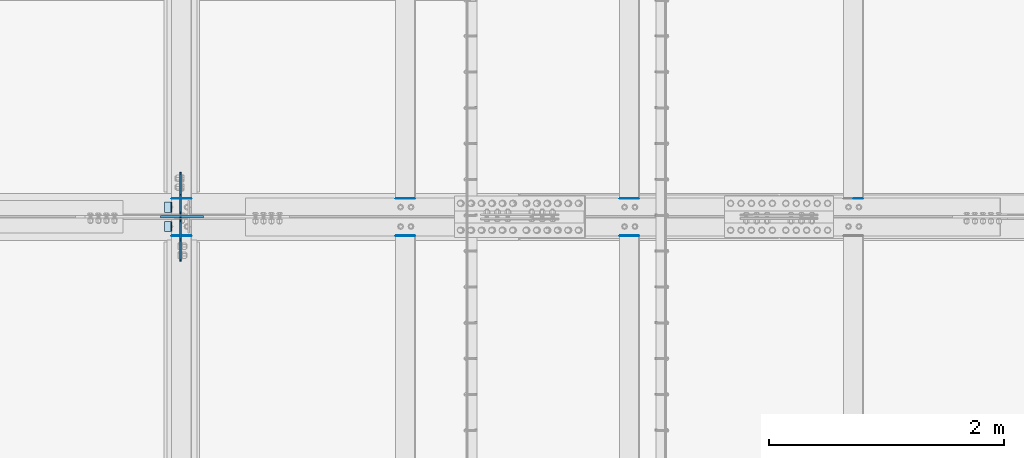
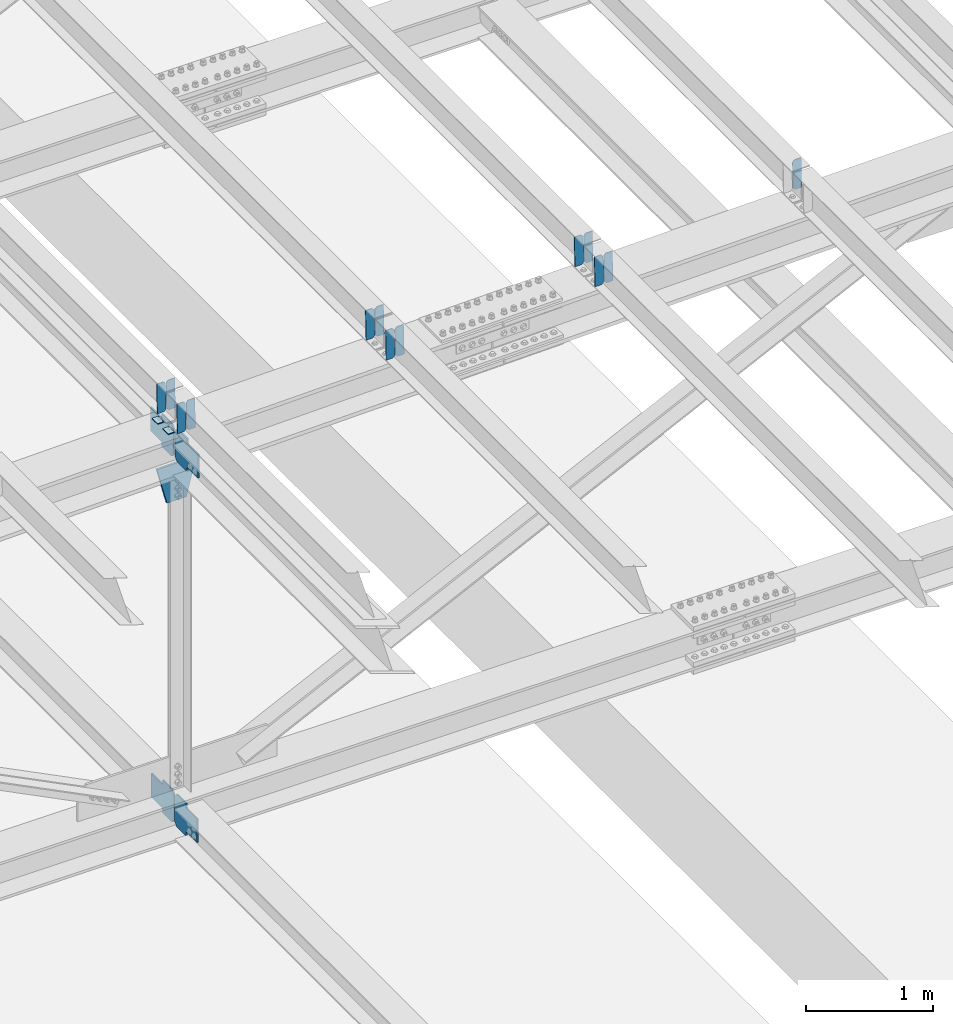
# One storey, part 3311 of 3843: 20 plates, 9 elements without a shape of their own.
"""IFC2X3 building model written with IfcOpenShell, lengths in millimetres."""

import ifcopenshell
import ifcopenshell.guid

model = None  # the IFC model being written
_history = None  # IfcOwnerHistory: only IFC2X3 demands one
_inside = {}  # id of a spatial element -> (the spatial element, [elements in it])
_under = {}  # id of a project, library or spatial element -> (it, [spatial elements below it])
_declared = {}  # id of a project -> (the project, [libraries it declares])
_typed = {}  # id of a type object -> (the type object, [elements of that type])
_made_of = {}  # id of a material, layer set ... -> (it, [elements and type objects made of it])


def new_model(schema):
    """Start an empty IFC model of exactly this schema.

    Asked for "IFC4X3", IfcOpenShell would pick the latest addendum, in which some entities
    have other attributes; the version numbers below select the first issue.
    IFC2X3 requires an IfcOwnerHistory on every rooted entity: one is made here for all.
    """
    global model, _history
    if schema == "IFC4X3":
        model = ifcopenshell.file(schema_version=(4, 3, 0, 0))
    else:
        model = ifcopenshell.file(schema=schema)
    _inside.clear()
    _under.clear()
    _declared.clear()
    _typed.clear()
    _made_of.clear()
    _history = None
    if model.schema == "IFC2X3":
        org = make("IfcOrganization", Name="unknown")
        user = make(
            "IfcPersonAndOrganization",
            ThePerson=make("IfcPerson", FamilyName="unknown"),
            TheOrganization=org,
        )
        app = make(
            "IfcApplication",
            ApplicationDeveloper=org,
            Version="unknown",
            ApplicationFullName="unknown",
            ApplicationIdentifier="unknown",
        )
        _history = make(
            "IfcOwnerHistory",
            OwningUser=user,
            OwningApplication=app,
            ChangeAction="ADDED",
            CreationDate=0,
        )
    return model


def make(cls, **values):
    """One entity of the class cls with the attributes given. An attribute that is None is left unset."""
    return model.create_entity(
        cls, **{name: value for name, value in values.items() if value is not None}
    )


def rooted(cls, **values):
    """An entity with a GlobalId (a new one), such as an element, a storey or a relation."""
    return make(cls, GlobalId=ifcopenshell.guid.new(), OwnerHistory=_history, **values)


def si_unit(unit_type, name, prefix=None):
    """IfcSIUnit, for example si_unit("LENGTHUNIT", "METRE", prefix="MILLI")."""
    return make("IfcSIUnit", UnitType=unit_type, Prefix=prefix, Name=name)


def assignment(units):
    """IfcUnitAssignment: the units of a project."""
    return None if units is None else make("IfcUnitAssignment", Units=units)


def point(xyz):
    """IfcCartesianPoint."""
    return None if xyz is None else make("IfcCartesianPoint", Coordinates=xyz)


def direction(xyz):
    """IfcDirection."""
    return None if xyz is None else make("IfcDirection", DirectionRatios=xyz)


def frame(location, z_axis=None, x_axis=None):
    """IfcAxis2Placement3D, a coordinate frame: its origin and axes. An axis left out is left unset."""
    return make(
        "IfcAxis2Placement3D",
        Location=point(location),
        Axis=direction(z_axis),
        RefDirection=direction(x_axis),
    )


def origin_with_axes():
    """The frame at (0, 0, 0) with the z axis (0, 0, 1) and the x axis (1, 0, 0) written out."""
    return frame((0.0, 0.0, 0.0), z_axis=(0.0, 0.0, 1.0), x_axis=(1.0, 0.0, 0.0))


def place(relative_to, where):
    """IfcLocalPlacement: puts the frame where relative to a parent placement (None: the world)."""
    return make(
        "IfcLocalPlacement", PlacementRelTo=relative_to, RelativePlacement=where
    )


def context(
    kind, dimensions, precision=None, world=None, true_north=None, identifier=None
):
    """IfcGeometricRepresentationContext, for example the 3D "Model" context."""
    return make(
        "IfcGeometricRepresentationContext",
        ContextIdentifier=identifier,
        ContextType=kind,
        CoordinateSpaceDimension=dimensions,
        Precision=precision,
        WorldCoordinateSystem=world,
        TrueNorth=true_north,
    )


def subcontext(parent, identifier, kind, view, scale=None):
    """IfcGeometricRepresentationSubContext, for example "Body" below "Model"."""
    return make(
        "IfcGeometricRepresentationSubContext",
        ContextIdentifier=identifier,
        ContextType=kind,
        ParentContext=parent,
        TargetScale=scale,
        TargetView=view,
    )


def project(units=None, contexts=None):
    """IfcProject with its units and contexts."""
    return rooted(
        "IfcProject",
        Name="project",
        RepresentationContexts=contexts,
        UnitsInContext=assignment(units),
    )


def spatial(cls, under=None, at=None, **own):
    """A site, building, storey or space (cls), placed at a placement, below another one or the project."""
    s = rooted(cls, ObjectPlacement=at, **own)
    if under is not None:
        _under.setdefault(under.id(), (under, []))[1].append(s)
    return s


def faces_of(points, faces, orient=None, outer=None):
    """IfcFace entities. A face is a list of loops; a loop is a list of indices into points, from 0.

    orient and outer hold one flag for each loop. By default every Orientation is true, the
    first loop of a face is its IfcFaceOuterBound and the others are IfcFaceBound.
    """
    made = []
    for i, loops in enumerate(faces):
        bounds = []
        for j, loop in enumerate(loops):
            is_outer = j == 0 if outer is None else outer[i][j]
            bounds.append(
                make(
                    "IfcFaceOuterBound" if is_outer else "IfcFaceBound",
                    Bound=make("IfcPolyLoop", Polygon=[points[k] for k in loop]),
                    Orientation=True if orient is None else orient[i][j],
                )
            )
        made.append(make("IfcFace", Bounds=bounds))
    return made


def faceted_brep(points, faces, orient=None, outer=None, voids=None):
    """IfcFacetedBrep: a solid bounded by flat faces; with voids (closed shells), ...WithVoids."""
    shared = [point(p) for p in points]
    hull = make("IfcClosedShell", CfsFaces=faces_of(shared, faces, orient, outer))
    if voids is None:
        return make("IfcFacetedBrep", Outer=hull)
    return make(
        "IfcFacetedBrepWithVoids",
        Outer=hull,
        Voids=[
            make(cls, CfsFaces=faces_of(shared, fs, o, b)) for cls, fs, o, b in voids
        ],
    )


def shape(context_of_items, identifier, shape_type, items):
    """IfcShapeRepresentation: the items that make up one representation, for example the "Body"."""
    return make(
        "IfcShapeRepresentation",
        ContextOfItems=context_of_items,
        RepresentationIdentifier=identifier,
        RepresentationType=shape_type,
        Items=items,
    )


def material(Name=None, Category=None):
    """IfcMaterial."""
    return make("IfcMaterial", Name=Name, Category=Category)


def made_of(thing, what):
    """Note that an element or type object is made of a material, layer set ...; save() writes the relation."""
    if what is not None:
        _made_of.setdefault(what.id(), (what, []))[1].append(thing)
    return thing


def type_object(cls, material=None, **own):
    """A type object (cls), such as IfcWallType, which elements share."""
    return made_of(rooted(cls, **own), material)


def element(
    cls,
    number,
    at=None,
    inside=None,
    cuts=None,
    type_object=None,
    material=None,
    context=None,
    identifier="Body",
    shape_type=None,
    held_by="IfcProductDefinitionShape",
    body=None,
    shapes=None,
    **own,
):
    """One element of the class cls, such as IfcWall. Its Tag is "e" and its number.

    at: its placement. inside: the storey or other place that contains it. cuts: it is an
    opening in that element (IfcRelVoidsElement). A single representation is given by context,
    identifier, shape_type and body (its items); several are given by shapes. held_by: the class
    of the entity that holds the representations. save() writes the other relations.
    """
    e = rooted(cls, Tag="e%d" % number, ObjectPlacement=at, **own)
    if body is not None:
        shapes = [shape(context, identifier, shape_type, body)]
    if shapes is not None:
        e.Representation = make(held_by, Representations=shapes)
    if inside is not None:
        _inside.setdefault(inside.id(), (inside, []))[1].append(e)
    if cuts is not None:
        rooted(
            "IfcRelVoidsElement", RelatingBuildingElement=cuts, RelatedOpeningElement=e
        )
    if type_object is not None:
        _typed.setdefault(type_object.id(), (type_object, []))[1].append(e)
    return made_of(e, material)


def aggregate(whole, parts):
    """IfcRelAggregates: a whole, such as a stair, and the parts it consists of."""
    return rooted("IfcRelAggregates", RelatingObject=whole, RelatedObjects=parts)


def save(model, path):
    """Write the relations noted so far, then the file.

    IfcRelAggregates (storeys below a building ...), IfcRelContainedInSpatialStructure (elements
    in a storey), IfcRelDefinesByType, IfcRelAssociatesMaterial and IfcRelDeclares: one each for
    every whole, place, type object, material and project.
    """
    for whole, parts in _under.values():
        aggregate(whole, parts)
    for where, things in _inside.values():
        rooted(
            "IfcRelContainedInSpatialStructure",
            RelatedElements=things,
            RelatingStructure=where,
        )
    for kind, things in _typed.values():
        rooted("IfcRelDefinesByType", RelatedObjects=things, RelatingType=kind)
    for what, things in _made_of.values():
        rooted("IfcRelAssociatesMaterial", RelatedObjects=things, RelatingMaterial=what)
    for by, libraries in _declared.values():
        rooted("IfcRelDeclares", RelatingContext=by, RelatedDefinitions=libraries)
    model.write(path)


model = new_model("IFC2X3")

# Units and contexts
model_context = context("Model", 3, precision=1e-05, world=origin_with_axes())
body_context = subcontext(model_context, "Body", "Model", "MODEL_VIEW")
ifc_project = project(units=[si_unit("LENGTHUNIT", "METRE", prefix="MILLI"), si_unit("AREAUNIT", "SQUARE_METRE"), si_unit("VOLUMEUNIT", "CUBIC_METRE"), si_unit("MASSUNIT", "GRAM", prefix="KILO"), si_unit("TIMEUNIT", "SECOND"), si_unit("PLANEANGLEUNIT", "RADIAN"), si_unit("SOLIDANGLEUNIT", "STERADIAN"), si_unit("THERMODYNAMICTEMPERATUREUNIT", "DEGREE_CELSIUS"), si_unit("LUMINOUSINTENSITYUNIT", "LUMEN")], contexts=[model_context])

# Site, building, storey
site_placement = place(None, origin_with_axes())
site = spatial("IfcSite", under=ifc_project, at=site_placement, CompositionType="ELEMENT")
building_placement = place(site_placement, origin_with_axes())
building = spatial("IfcBuilding", under=site, at=building_placement, Name="Undefined", CompositionType="ELEMENT")
storey_placement = place(building_placement, origin_with_axes())
storey = spatial("IfcBuildingStorey", under=building, at=storey_placement, Name="Undefined", CompositionType="ELEMENT", Elevation=0.0)

# Assembly, plates
assembly_1_placement = place(storey_placement, origin_with_axes())
assembly_1 = element("IfcElementAssembly", 1, at=assembly_1_placement, inside=storey, Name="BEAM", AssemblyPlace="NOTDEFINED", PredefinedType="RIGID_FRAME")
ifc_material = material(Name="STEEL/A572-50")
plate_type_1 = type_object("IfcPlateType", PredefinedType="NOTDEFINED")
plate_1_placement = place(assembly_1_placement, frame((62718.6964783116, 50714.3857957875, 46077.1630974841), z_axis=(-0.0211520984675226, -0.000371508000112954, 0.999776200312963), x_axis=(-0.999776269354799, 8.33600001439919e-06, -0.0211520960075334)))
plate_1 = element("IfcPlate", 2, at=plate_1_placement, type_object=plate_type_1, material=ifc_material, Name="PLATE", context=body_context, shape_type="Brep", body=[
    faceted_brep([(0.0, -3.17499999999927, 0.0), (6.83940015733242e-10, -3.17499999996653, 288.924999998613), (6.54836185276508e-10, 3.17500000001746, 288.924999998591), (0.0, 3.17499999999927, 0.0), (60.3250007643655, -3.17500000017753, 288.924999998606), (60.3250007643219, 3.17499999979918, 288.924999998584), (79.3750000013097, -3.17500000025029, 269.875000761494), (79.375000001266, 3.17499999972642, 269.875000761487), (79.375000000713, -3.17500000026484, 19.0499992370605), (79.3750000006985, 3.17499999971187, 19.0499992370533), (60.325000763667, -3.17500000020664, -1.45519152283669e-11), (60.3250007636234, 3.17499999977736, -3.63797880709171e-11)], [[[0, 1, 2, 3]], [[1, 4, 5, 2]], [[4, 6, 7, 5]], [[6, 8, 9, 7]], [[8, 10, 11, 9]], [[10, 0, 3, 11]], [[5, 7, 9, 11, 3, 2]], [[10, 8, 6, 4, 1, 0]]]),
])
plate_2_placement = place(assembly_1_placement, frame((62632.990657622, 50714.3864695822, 46075.3498340078), z_axis=(-0.0211520984675226, -0.000371508000112954, 0.999776200312963), x_axis=(-0.999776269354799, 8.33600001439919e-06, -0.0211520960075334)))
plate_2 = element("IfcPlate", 3, at=plate_2_placement, type_object=plate_type_1, material=ifc_material, Name="PLATE", context=body_context, shape_type="Brep", body=[
    faceted_brep([(4.36557456851006e-11, -3.17499999998836, 19.0499992370969), (6.11180439591408e-10, -3.17499999996653, 269.875000761516), (5.96628524363041e-10, 3.17500000001746, 269.875000761502), (1.45519152283669e-11, 3.17499999998836, 19.0499992370824), (19.0499992376572, -3.17500000003201, 288.924999998606), (19.0499992376281, 3.1749999999447, 288.924999998584), (79.3750000013242, -3.17500000025029, 288.924999998591), (79.3750000013097, 3.1749999997337, 288.92499999857), (79.3750000006548, -3.17500000026484, -2.18278728425503e-11), (79.3750000006403, 3.17499999969732, -2.91038304567337e-11), (19.0499992370023, -3.17500000005384, 0.0), (19.0499992369587, 3.17499999992287, -1.45519152283669e-11)], [[[0, 1, 2, 3]], [[1, 4, 5, 2]], [[4, 6, 7, 5]], [[6, 8, 9, 7]], [[8, 10, 11, 9]], [[10, 0, 3, 11]], [[5, 7, 9, 11, 3, 2]], [[10, 8, 6, 4, 1, 0]]]),
])

assembly_2_placement = place(storey_placement, origin_with_axes())
assembly_2 = element("IfcElementAssembly", 4, at=assembly_2_placement, inside=storey, Name="BEAM", AssemblyPlace="NOTDEFINED", PredefinedType="RIGID_FRAME")
plate_3_placement = place(assembly_2_placement, frame((62718.6964784438, 50397.3350534356, 46076.8025377101), z_axis=(-0.0211520982314614, -0.0018756519998351, 0.999774509912101), x_axis=(-0.999776269352655, 3.88860000353947e-05, -0.0211520620074247)))
plate_3 = element("IfcPlate", 5, at=plate_3_placement, type_object=plate_type_1, material=ifc_material, Name="PLATE", context=body_context, shape_type="Brep", body=[
    faceted_brep([(0.0, -3.17499999999927, 0.0), (6.83940015733242e-10, -3.17499999996653, 288.924999998613), (6.54836185276508e-10, 3.17500000001746, 288.924999998591), (0.0, 3.17499999999927, 0.0), (60.3250007643655, -3.17500000017753, 288.924999998606), (60.3250007643219, 3.17499999979918, 288.924999998584), (79.3750000013097, -3.17500000025029, 269.875000761494), (79.375000001266, 3.17499999972642, 269.875000761487), (79.375000000713, -3.17500000026484, 19.0499992370605), (79.3750000006985, 3.17499999971187, 19.0499992370533), (60.325000763667, -3.17500000020664, -1.45519152283669e-11), (60.3250007636234, 3.17499999977736, -3.63797880709171e-11)], [[[0, 1, 2, 3]], [[1, 4, 5, 2]], [[4, 6, 7, 5]], [[6, 8, 9, 7]], [[8, 10, 11, 9]], [[10, 0, 3, 11]], [[5, 7, 9, 11, 3, 2]], [[10, 8, 6, 4, 1, 0]]]),
])
plate_4_placement = place(assembly_2_placement, frame((62632.9906577541, 50397.3384552489, 46074.9892772999), z_axis=(-0.0211520982314614, -0.0018756519998351, 0.999774509912101), x_axis=(-0.999776269352655, 3.88860000353947e-05, -0.0211520620074247)))
plate_4 = element("IfcPlate", 6, at=plate_4_placement, type_object=plate_type_1, material=ifc_material, Name="PLATE", context=body_context, shape_type="Brep", body=[
    faceted_brep([(4.36557456851006e-11, -3.17499999998836, 19.0499992370969), (6.11180439591408e-10, -3.17499999996653, 269.875000761516), (5.96628524363041e-10, 3.17500000001746, 269.875000761502), (1.45519152283669e-11, 3.17499999998836, 19.0499992370824), (19.0499992376572, -3.17500000003201, 288.924999998606), (19.0499992376281, 3.1749999999447, 288.924999998584), (79.3750000013242, -3.17500000025029, 288.924999998591), (79.3750000013097, 3.1749999997337, 288.92499999857), (79.3750000006548, -3.17500000026484, -2.18278728425503e-11), (79.3750000006403, 3.17499999969732, -2.91038304567337e-11), (19.0499992370023, -3.17500000005384, 0.0), (19.0499992369587, 3.17499999992287, -1.45519152283669e-11)], [[[0, 1, 2, 3]], [[1, 4, 5, 2]], [[4, 6, 7, 5]], [[6, 8, 9, 7]], [[8, 10, 11, 9]], [[10, 0, 3, 11]], [[5, 7, 9, 11, 3, 2]], [[10, 8, 6, 4, 1, 0]]]),
])

# Assembly, plate
assembly_3_placement = place(storey_placement, origin_with_axes())
assembly_3 = element("IfcElementAssembly", 7, at=assembly_3_placement, inside=storey, Name="BEAM", AssemblyPlace="NOTDEFINED", PredefinedType="RIGID_FRAME")
plate_5_placement = place(assembly_3_placement, frame((68433.6964783081, 50714.4100213634, 46201.4245192417), z_axis=(-0.0211520981762442, -0.000452761999920767, 0.999776166824012), x_axis=(-0.999776269357268, 1.0337000006824e-05, -0.0211520950075907)))
plate_5 = element("IfcPlate", 8, at=plate_5_placement, type_object=plate_type_1, material=ifc_material, Name="PLATE", context=body_context, shape_type="Brep", body=[
    faceted_brep([(0.0, -3.17499999999927, 0.0), (6.83940015733242e-10, -3.17499999996653, 288.924999998613), (6.54836185276508e-10, 3.17500000001746, 288.924999998591), (0.0, 3.17499999999927, 0.0), (60.3250007643655, -3.17500000017753, 288.924999998606), (60.3250007643219, 3.17499999979918, 288.924999998584), (79.3750000013097, -3.17500000025029, 269.875000761494), (79.375000001266, 3.17499999972642, 269.875000761487), (79.375000000713, -3.17500000026484, 19.0499992370605), (79.3750000006985, 3.17499999971187, 19.0499992370533), (60.325000763667, -3.17500000020664, -1.45519152283669e-11), (60.3250007636234, 3.17499999977736, -3.63797880709171e-11)], [[[0, 1, 2, 3]], [[1, 4, 5, 2]], [[4, 6, 7, 5]], [[6, 8, 9, 7]], [[8, 10, 11, 9]], [[10, 0, 3, 11]], [[5, 7, 9, 11, 3, 2]], [[10, 8, 6, 4, 1, 0]]]),
])
aggregate(assembly_3, [plate_5])

# Assembly, plates
assembly_4_placement = place(storey_placement, origin_with_axes())
assembly_4 = element("IfcElementAssembly", 9, at=assembly_4_placement, inside=storey, Name="BEAM", AssemblyPlace="NOTDEFINED", PredefinedType="RIGID_FRAME")
plate_6_placement = place(assembly_4_placement, frame((66528.6964783553, 50714.4019529587, 46160.6652783432), z_axis=(-0.0211520979246561, -0.000425699999883364, 0.999776178718465), x_axis=(-0.999776269351943, 8.67199997865676e-06, -0.0211520960074328)))
plate_6 = element("IfcPlate", 10, at=plate_6_placement, type_object=plate_type_1, material=ifc_material, Name="PLATE", context=body_context, shape_type="Brep", body=[
    faceted_brep([(0.0, -3.17499999999927, 0.0), (6.83940015733242e-10, -3.17499999996653, 288.924999998613), (6.54836185276508e-10, 3.17500000001746, 288.924999998591), (0.0, 3.17499999999927, 0.0), (60.3250007643655, -3.17500000017753, 288.924999998606), (60.3250007643219, 3.17499999979918, 288.924999998584), (79.3750000013097, -3.17500000025029, 269.875000761494), (79.375000001266, 3.17499999972642, 269.875000761487), (79.375000000713, -3.17500000026484, 19.0499992370605), (79.3750000006985, 3.17499999971187, 19.0499992370533), (60.325000763667, -3.17500000020664, -1.45519152283669e-11), (60.3250007636234, 3.17499999977736, -3.63797880709171e-11)], [[[0, 1, 2, 3]], [[1, 4, 5, 2]], [[4, 6, 7, 5]], [[6, 8, 9, 7]], [[8, 10, 11, 9]], [[10, 0, 3, 11]], [[5, 7, 9, 11, 3, 2]], [[10, 8, 6, 4, 1, 0]]]),
])
plate_7_placement = place(assembly_4_placement, frame((66442.9906576641, 50714.4027250379, 46158.8520149073), z_axis=(-0.0211520979246561, -0.000425699999883364, 0.999776178718465), x_axis=(-0.999776269351943, 8.67199997865676e-06, -0.0211520960074328)))
plate_7 = element("IfcPlate", 11, at=plate_7_placement, type_object=plate_type_1, material=ifc_material, Name="PLATE", context=body_context, shape_type="Brep", body=[
    faceted_brep([(4.36557456851006e-11, -3.17499999998836, 19.0499992370969), (6.11180439591408e-10, -3.17499999996653, 269.875000761516), (5.96628524363041e-10, 3.17500000001746, 269.875000761502), (1.45519152283669e-11, 3.17499999998836, 19.0499992370824), (19.0499992376572, -3.17500000003201, 288.924999998606), (19.0499992376281, 3.1749999999447, 288.924999998584), (79.3750000013242, -3.17500000025029, 288.924999998591), (79.3750000013097, 3.1749999997337, 288.92499999857), (79.3750000006548, -3.17500000026484, -2.18278728425503e-11), (79.3750000006403, 3.17499999969732, -2.91038304567337e-11), (19.0499992370023, -3.17500000005384, 0.0), (19.0499992369587, 3.17499999992287, -1.45519152283669e-11)], [[[0, 1, 2, 3]], [[1, 4, 5, 2]], [[4, 6, 7, 5]], [[6, 8, 9, 7]], [[8, 10, 11, 9]], [[10, 0, 3, 11]], [[5, 7, 9, 11, 3, 2]], [[10, 8, 6, 4, 1, 0]]]),
])
aggregate(assembly_4, [plate_6, plate_7])

assembly_5_placement = place(storey_placement, origin_with_axes())
assembly_5 = element("IfcElementAssembly", 12, at=assembly_5_placement, inside=storey, Name="BEAM", AssemblyPlace="NOTDEFINED", PredefinedType="RIGID_FRAME")
plate_8_placement = place(assembly_5_placement, frame((66528.696478291, 50397.3735063155, 46160.2755842455), z_axis=(-0.0211520975136227, -0.00200431100054993, 0.999774260274882), x_axis=(-0.999776269341419, 4.27870000128944e-05, -0.0211520550071887)))
plate_8 = element("IfcPlate", 13, at=plate_8_placement, type_object=plate_type_1, material=ifc_material, Name="PLATE", context=body_context, shape_type="Brep", body=[
    faceted_brep([(0.0, -3.17499999999927, 0.0), (6.83940015733242e-10, -3.17499999996653, 288.924999998613), (6.54836185276508e-10, 3.17500000001746, 288.924999998591), (0.0, 3.17499999999927, 0.0), (60.3250007643655, -3.17500000017753, 288.924999998606), (60.3250007643219, 3.17499999979918, 288.924999998584), (79.3750000013097, -3.17500000025029, 269.875000761494), (79.375000001266, 3.17499999972642, 269.875000761487), (79.375000000713, -3.17500000026484, 19.0499992370605), (79.3750000006985, 3.17499999971187, 19.0499992370533), (60.325000763667, -3.17500000020664, -1.45519152283669e-11), (60.3250007636234, 3.17499999977736, -3.63797880709171e-11)], [[[0, 1, 2, 3]], [[1, 4, 5, 2]], [[4, 6, 7, 5]], [[6, 8, 9, 7]], [[8, 10, 11, 9]], [[10, 0, 3, 11]], [[5, 7, 9, 11, 3, 2]], [[10, 8, 6, 4, 1, 0]]]),
])
plate_9_placement = place(assembly_5_placement, frame((66442.9906575998, 50397.3771414718, 46158.4623242876), z_axis=(-0.0211520975136227, -0.00200431100054993, 0.999774260274882), x_axis=(-0.999776269341419, 4.27870000128944e-05, -0.0211520550071887)))
plate_9 = element("IfcPlate", 14, at=plate_9_placement, type_object=plate_type_1, material=ifc_material, Name="PLATE", context=body_context, shape_type="Brep", body=[
    faceted_brep([(4.36557456851006e-11, -3.17499999998836, 19.0499992370969), (6.11180439591408e-10, -3.17499999996653, 269.875000761516), (5.96628524363041e-10, 3.17500000001746, 269.875000761502), (1.45519152283669e-11, 3.17499999998836, 19.0499992370824), (19.0499992376572, -3.17500000003201, 288.924999998606), (19.0499992376281, 3.1749999999447, 288.924999998584), (79.3750000013242, -3.17500000025029, 288.924999998591), (79.3750000013097, 3.1749999997337, 288.92499999857), (79.3750000006548, -3.17500000026484, -2.18278728425503e-11), (79.3750000006403, 3.17499999969732, -2.91038304567337e-11), (19.0499992370023, -3.17500000005384, 0.0), (19.0499992369587, 3.17499999992287, -1.45519152283669e-11)], [[[0, 1, 2, 3]], [[1, 4, 5, 2]], [[4, 6, 7, 5]], [[6, 8, 9, 7]], [[8, 10, 11, 9]], [[10, 0, 3, 11]], [[5, 7, 9, 11, 3, 2]], [[10, 8, 6, 4, 1, 0]]]),
])
aggregate(assembly_5, [plate_8, plate_9])

assembly_6_placement = place(storey_placement, origin_with_axes())
assembly_6 = element("IfcElementAssembly", 15, at=assembly_6_placement, inside=storey, Name="BEAM", AssemblyPlace="NOTDEFINED", PredefinedType="RIGID_FRAME")
plate_10_placement = place(assembly_6_placement, frame((64623.6964783358, 50714.3938777407, 46119.2742660517), z_axis=(-0.021152097688544, -0.000398615999954926, 0.999776189888847), x_axis=(-0.999776269351943, 8.67199997865676e-06, -0.0211520960074328)))
plate_10 = element("IfcPlate", 16, at=plate_10_placement, type_object=plate_type_1, material=ifc_material, Name="PLATE", context=body_context, shape_type="Brep", body=[
    faceted_brep([(0.0, -3.17499999999927, 0.0), (6.83940015733242e-10, -3.17499999996653, 288.924999998613), (6.54836185276508e-10, 3.17500000001746, 288.924999998591), (0.0, 3.17499999999927, 0.0), (60.3250007643655, -3.17500000017753, 288.924999998606), (60.3250007643219, 3.17499999979918, 288.924999998584), (79.3750000013097, -3.17500000025029, 269.875000761494), (79.375000001266, 3.17499999972642, 269.875000761487), (79.375000000713, -3.17500000026484, 19.0499992370605), (79.3750000006985, 3.17499999971187, 19.0499992370533), (60.325000763667, -3.17500000020664, -1.45519152283669e-11), (60.3250007636234, 3.17499999977736, -3.63797880709171e-11)], [[[0, 1, 2, 3]], [[1, 4, 5, 2]], [[4, 6, 7, 5]], [[6, 8, 9, 7]], [[8, 10, 11, 9]], [[10, 0, 3, 11]], [[5, 7, 9, 11, 3, 2]], [[10, 8, 6, 4, 1, 0]]]),
])
plate_11_placement = place(assembly_6_placement, frame((64537.9906576464, 50714.394600698, 46117.4610025951), z_axis=(-0.021152097688544, -0.000398615999954926, 0.999776189888847), x_axis=(-0.999776269351943, 8.67199997865676e-06, -0.0211520960074328)))
plate_11 = element("IfcPlate", 17, at=plate_11_placement, type_object=plate_type_1, material=ifc_material, Name="PLATE", context=body_context, shape_type="Brep", body=[
    faceted_brep([(4.36557456851006e-11, -3.17499999998836, 19.0499992370969), (6.11180439591408e-10, -3.17499999996653, 269.875000761516), (5.96628524363041e-10, 3.17500000001746, 269.875000761502), (1.45519152283669e-11, 3.17499999998836, 19.0499992370824), (19.0499992376572, -3.17500000003201, 288.924999998606), (19.0499992376281, 3.1749999999447, 288.924999998584), (79.3750000013242, -3.17500000025029, 288.924999998591), (79.3750000013097, 3.1749999997337, 288.92499999857), (79.3750000006548, -3.17500000026484, -2.18278728425503e-11), (79.3750000006403, 3.17499999969732, -2.91038304567337e-11), (19.0499992370023, -3.17500000005384, 0.0), (19.0499992369587, 3.17499999992287, -1.45519152283669e-11)], [[[0, 1, 2, 3]], [[1, 4, 5, 2]], [[4, 6, 7, 5]], [[6, 8, 9, 7]], [[8, 10, 11, 9]], [[10, 0, 3, 11]], [[5, 7, 9, 11, 3, 2]], [[10, 8, 6, 4, 1, 0]]]),
])
aggregate(assembly_6, [plate_10, plate_11])

assembly_7_placement = place(storey_placement, origin_with_axes())
assembly_7 = element("IfcElementAssembly", 18, at=assembly_7_placement, inside=storey, Name="BEAM", AssemblyPlace="NOTDEFINED", PredefinedType="RIGID_FRAME")
plate_12_placement = place(assembly_7_placement, frame((64623.6964782835, 50397.3557139552, 46118.8983632192), z_axis=(-0.0211520980268542, -0.00194478699965839, 0.999774377823611), x_axis=(-0.999776269338345, 4.08370000139469e-05, -0.0211520590071252)))
plate_12 = element("IfcPlate", 19, at=plate_12_placement, type_object=plate_type_1, material=ifc_material, Name="PLATE", context=body_context, shape_type="Brep", body=[
    faceted_brep([(0.0, -3.17499999999927, 0.0), (6.83940015733242e-10, -3.17499999996653, 288.924999998613), (6.54836185276508e-10, 3.17500000001746, 288.924999998591), (0.0, 3.17499999999927, 0.0), (60.3250007643655, -3.17500000017753, 288.924999998606), (60.3250007643219, 3.17499999979918, 288.924999998584), (79.3750000013097, -3.17500000025029, 269.875000761494), (79.375000001266, 3.17499999972642, 269.875000761487), (79.375000000713, -3.17500000026484, 19.0499992370605), (79.3750000006985, 3.17499999971187, 19.0499992370533), (60.325000763667, -3.17500000020664, -1.45519152283669e-11), (60.3250007636234, 3.17499999977736, -3.63797880709171e-11)], [[[0, 1, 2, 3]], [[1, 4, 5, 2]], [[4, 6, 7, 5]], [[6, 8, 9, 7]], [[8, 10, 11, 9]], [[10, 0, 3, 11]], [[5, 7, 9, 11, 3, 2]], [[10, 8, 6, 4, 1, 0]]]),
])
plate_13_placement = place(assembly_7_placement, frame((64537.9906575942, 50397.3592411556, 46117.0851030491), z_axis=(-0.0211520980268542, -0.00194478699965839, 0.999774377823611), x_axis=(-0.999776269338345, 4.08370000139469e-05, -0.0211520590071252)))
plate_13 = element("IfcPlate", 20, at=plate_13_placement, type_object=plate_type_1, material=ifc_material, Name="PLATE", context=body_context, shape_type="Brep", body=[
    faceted_brep([(4.36557456851006e-11, -3.17499999998836, 19.0499992370969), (6.11180439591408e-10, -3.17499999996653, 269.875000761516), (5.96628524363041e-10, 3.17500000001746, 269.875000761502), (1.45519152283669e-11, 3.17499999998836, 19.0499992370824), (19.0499992376572, -3.17500000003201, 288.924999998606), (19.0499992376281, 3.1749999999447, 288.924999998584), (79.3750000013242, -3.17500000025029, 288.924999998591), (79.3750000013097, 3.1749999997337, 288.92499999857), (79.3750000006548, -3.17500000026484, -2.18278728425503e-11), (79.3750000006403, 3.17499999969732, -2.91038304567337e-11), (19.0499992370023, -3.17500000005384, 0.0), (19.0499992369587, 3.17499999992287, -1.45519152283669e-11)], [[[0, 1, 2, 3]], [[1, 4, 5, 2]], [[4, 6, 7, 5]], [[6, 8, 9, 7]], [[8, 10, 11, 9]], [[10, 0, 3, 11]], [[5, 7, 9, 11, 3, 2]], [[10, 8, 6, 4, 1, 0]]]),
])
aggregate(assembly_7, [plate_12, plate_13])

# Plate
plate_type_2 = type_object("IfcPlateType", PredefinedType="NOTDEFINED")
plate_14_placement = place(assembly_1_placement, frame((62553.7677319044, 50685.7, 46067.2644651229), z_axis=(0.0, -1.0, 0.0), x_axis=(-0.999776270257024, 0.0, -0.0211520550054595)))
plate_14 = element("IfcPlate", 21, at=plate_14_placement, type_object=plate_type_2, material=ifc_material, Name="PLATE", context=body_context, shape_type="Brep", body=[
    faceted_brep([(9.52499999982683, -4.7625000001135, 88.8999999999942), (0.0, 4.76249999999709, 88.9000015258789), (0.0, 4.76249999999709, 0.0), (9.52499999981956, -4.76249999999709, 0.0), (63.4999984608512, -4.76249999988795, 88.8999999999796), (63.4999984608367, -4.76249999988795, -1.45519152283669e-11), (63.4999984608221, 4.76250000013533, -1.45519152283669e-11), (63.4999984608367, 4.76250000013533, 88.8999999999796)], [[[0, 1, 2, 3]], [[4, 5, 6, 7]], [[5, 4, 0, 3]], [[6, 5, 3, 2]], [[7, 6, 2, 1]], [[4, 7, 1, 0]]]),
])

aggregate(assembly_1, [plate_1, plate_2, plate_14])

plate_15_placement = place(assembly_2_placement, frame((62553.7677319044, 50520.6000015258, 46067.2644651229), z_axis=(0.0, -1.0, 0.0), x_axis=(-0.999776270257024, 0.0, -0.0211520550054595)))
plate_15 = element("IfcPlate", 22, at=plate_15_placement, type_object=plate_type_2, material=ifc_material, Name="PLATE", context=body_context, shape_type="Brep", body=[
    faceted_brep([(9.52499999982683, -4.7625000001135, 88.8999999999942), (0.0, 4.76249999999709, 88.9000015258789), (0.0, 4.76249999999709, 0.0), (9.52499999981956, -4.76249999999709, 0.0), (63.4999984608512, -4.76249999988795, 88.8999999999796), (63.4999984608367, -4.76249999988795, -1.45519152283669e-11), (63.4999984608221, 4.76250000013533, -1.45519152283669e-11), (63.4999984608367, 4.76250000013533, 88.8999999999796)], [[[0, 1, 2, 3]], [[4, 5, 6, 7]], [[5, 4, 0, 3]], [[6, 5, 3, 2]], [[7, 6, 2, 1]], [[4, 7, 1, 0]]]),
])

aggregate(assembly_2, [plate_3, plate_4, plate_15])

# Assembly, plates
assembly_8_placement = place(storey_placement, origin_with_axes())
assembly_8 = element("IfcElementAssembly", 23, at=assembly_8_placement, inside=storey, Name="BEAM", AssemblyPlace="NOTDEFINED", PredefinedType="RIGID_FRAME")
plate_type_3 = type_object("IfcPlateType", PredefinedType="NOTDEFINED")
plate_16_placement = place(assembly_8_placement, frame((62625.2874998483, 50565.84375, 42213.975276061), z_axis=(0.0, 0.707106781186548, 0.707106781186548), x_axis=(5.70000238222118e-08, 0.707106781186546, -0.707106781186546)))
plate_16 = element("IfcPlate", 24, at=plate_16_placement, type_object=plate_type_3, material=ifc_material, Name="PLATE", context=body_context, shape_type="Brep", body=[
    faceted_brep([(0.0, -6.3499999046162, 0.0), (-179.595038663459, -6.34999999999854, 179.595038663465), (-179.595038663459, 6.34999999999854, 179.595038663465), (7.27595761418343e-12, 6.3499999046162, 0.0), (-179.595038663467, -6.34999999999854, 224.496319268583), (-179.595038663467, 6.34999999999854, 224.496319268583), (-75.7608272640955, -6.34999999999854, 328.330530667954), (-75.7608272640955, 6.34999999999854, 328.330530667954), (-53.4094961520404, -6.34999999999854, 305.979199555906), (-53.4094961520404, 6.34999999999854, 305.979199555906), (-49.2893196839013, -6.34999999999854, 303.226185655425), (-49.2893196839013, 6.34999999999854, 303.226185655425), (-44.4292401658622, -6.34999999999854, 302.259455732841), (-44.4292401658622, 6.34999999999854, 302.259455732841), (-39.5691606478376, -6.34999999999854, 303.226185655425), (-39.5691606478376, 6.34999999999854, 303.226185655425), (-35.448984179684, -6.34999999999854, 305.979199555906), (-35.448984179684, 6.34999999999854, 305.979199555906), (81.2943455284894, -6.34999999999854, 422.722529264094), (81.2943455284894, 6.34999999999854, 422.722529264094), (242.938955706961, -6.34999999999854, 261.077919085612), (242.938955706961, 6.34999999999854, 261.077919085612), (126.195625998784, -6.34999999999854, 144.334589377453), (126.195625998784, 6.34999999999854, 144.334589377453), (123.442612098306, -6.34999999999854, 140.214412909307), (123.442612098306, 6.34999999999854, 140.214412909307), (122.475882175726, -6.34999999999854, 135.354333391268), (122.475882175726, 6.34999999999854, 135.354333391268), (123.442612098306, -6.34999999999854, 130.494253873228), (123.442612098306, 6.34999999999854, 130.494253873228), (126.195625998784, -6.34999999999854, 126.374077405097), (126.195625998784, 6.34999999999854, 126.374077405097), (148.735492004496, -6.35000000000582, 103.834211399357), (148.735492004496, 6.35000000000582, 103.834211399357), (44.9012806051323, -6.35000000000582, -1.45519152283669e-11), (44.9012806051323, 6.35000000000582, -1.45519152283669e-11)], [[[0, 1, 2, 3]], [[1, 4, 5, 2]], [[4, 6, 7, 5]], [[6, 8, 9, 7]], [[8, 10, 11, 9]], [[10, 12, 13, 11]], [[12, 14, 15, 13]], [[14, 16, 17, 15]], [[16, 18, 19, 17]], [[18, 20, 21, 19]], [[20, 22, 23, 21]], [[22, 24, 25, 23]], [[24, 26, 27, 25]], [[26, 28, 29, 27]], [[28, 30, 31, 29]], [[30, 32, 33, 31]], [[32, 34, 35, 33]], [[34, 0, 3, 35]], [[5, 7, 9, 11, 13, 15, 17, 19, 21, 23, 25, 27, 29, 31, 33, 35, 3, 2]], [[34, 32, 30, 28, 26, 24, 22, 20, 18, 16, 14, 12, 10, 8, 6, 4, 1, 0]]]),
])
plate_17_placement = place(assembly_8_placement, frame((62625.2874998286, 50551.5562499392, 42213.9752760469), z_axis=(0.0, -0.707106781186682, 0.707106781186413), x_axis=(0.0, -0.707106781186548, -0.707106781186548)))
plate_17 = element("IfcPlate", 25, at=plate_17_placement, type_object=plate_type_3, material=ifc_material, Name="PLATE", context=body_context, shape_type="Brep", body=[
    faceted_brep([(0.0, -6.3499999046162, 0.0), (-179.595038663459, -6.34999999999854, 179.595038663465), (-179.595038663459, 6.34999999999854, 179.595038663465), (7.27595761418343e-12, 6.3499999046162, 0.0), (-179.595038663467, -6.34999999999854, 224.496319268583), (-179.595038663467, 6.34999999999854, 224.496319268583), (-75.7608272640955, -6.34999999999854, 328.330530667954), (-75.7608272640955, 6.34999999999854, 328.330530667954), (-53.0029127149755, -6.34999999999854, 305.572616032998), (-53.0029127149755, 6.34999999999854, 305.572616032998), (-48.8827362468292, -6.34999999999854, 302.819602132531), (-48.8827362468292, 6.34999999999854, 302.819602132531), (-44.02265672879, -6.34999999999854, 301.85287220994), (-44.02265672879, 6.34999999999854, 301.85287220994), (-39.1625772107509, -6.34999999999854, 302.819602132524), (-39.1625772107509, 6.34999999999854, 302.819602132524), (-35.0424007426191, -6.34999999999854, 305.572616032998), (-35.0424007426191, 6.34999999999854, 305.572616032998), (81.7009290084825, -6.34999999999854, 422.315945784092), (81.7009290084825, 6.34999999999854, 422.315945784092), (243.345539186965, -6.34999999999854, 260.671335605624), (243.345539186965, 6.34999999999854, 260.671335605624), (126.602209435849, -6.34999999999854, 143.92800585453), (126.602209435849, 6.34999999999854, 143.92800585453), (123.849195535382, -6.34999999999854, 139.807829386384), (123.849195535382, 6.34999999999854, 139.807829386384), (122.882465612798, -6.34999999999854, 134.947749868352), (122.882465612798, 6.34999999999854, 134.947749868352), (123.849195535382, -6.34999999999854, 130.08767035032), (123.849195535382, 6.34999999999854, 130.08767035032), (126.602209435863, -6.34999999999854, 125.967493882181), (126.602209435863, 6.34999999999854, 125.967493882181), (148.735492004496, -6.35000000000582, 103.834211399357), (148.735492004496, 6.35000000000582, 103.834211399357), (44.9012806051323, -6.35000000000582, -1.45519152283669e-11), (44.9012806051323, 6.35000000000582, -1.45519152283669e-11)], [[[0, 1, 2, 3]], [[1, 4, 5, 2]], [[4, 6, 7, 5]], [[6, 8, 9, 7]], [[8, 10, 11, 9]], [[10, 12, 13, 11]], [[12, 14, 15, 13]], [[14, 16, 17, 15]], [[16, 18, 19, 17]], [[18, 20, 21, 19]], [[20, 22, 23, 21]], [[22, 24, 25, 23]], [[24, 26, 27, 25]], [[26, 28, 29, 27]], [[28, 30, 31, 29]], [[30, 32, 33, 31]], [[32, 34, 35, 33]], [[34, 0, 3, 35]], [[5, 7, 9, 11, 13, 15, 17, 19, 21, 23, 25, 27, 29, 31, 33, 35, 3, 2]], [[34, 32, 30, 28, 26, 24, 22, 20, 18, 16, 14, 12, 10, 8, 6, 4, 1, 0]]]),
])
aggregate(assembly_8, [plate_16, plate_17])

assembly_9_placement = place(storey_placement, origin_with_axes())
assembly_9 = element("IfcElementAssembly", 26, at=assembly_9_placement, inside=storey, Name="BEAM", AssemblyPlace="NOTDEFINED", PredefinedType="RIGID_FRAME")
plate_18_placement = place(assembly_9_placement, frame((62625.2874999088, 50547.5875000065, 45740.2020827849), z_axis=(0.0, -0.707106781186682, 0.707106781186413), x_axis=(0.0, -0.707106781186548, -0.707106781186548)))
plate_18 = element("IfcPlate", 27, at=plate_18_placement, type_object=plate_type_3, material=ifc_material, Name="PLATE", context=body_context, shape_type="Brep", body=[
    faceted_brep([(0.0, -6.3499999046162, 0.0), (-179.461821812436, -6.34999999999854, 179.461821812467), (-179.461821812436, 6.34999999999854, 179.461821812467), (7.27595761418343e-12, 6.3499999046162, 0.0), (-179.461821811959, -6.34999999999854, 224.363102418065), (-179.461821811959, 6.34999999999854, 224.363102418065), (-68.3311523045104, -6.34999999999854, 335.493771925481), (-68.3311523045104, 6.34999999999854, 335.493771925481), (-45.787133737249, -6.34999999999854, 312.949753347878), (-45.787133737249, 6.34999999999854, 312.949753347878), (-41.6669572691171, -6.34999999999854, 310.196739447405), (-41.6669572691171, 6.34999999999854, 310.196739447405), (-36.806877751078, -6.34999999999854, 309.230009524821), (-36.806877751078, 6.34999999999854, 309.230009524821), (-31.9467982330534, -6.34999999999854, 310.196739447401), (-31.9467982330534, 6.34999999999854, 310.196739447401), (-27.826621764907, -6.34999999999854, 312.949753347882), (-27.826621764907, 6.34999999999854, 312.949753347882), (88.9167079382314, -6.34999999999854, 429.69308305102), (88.9167079382314, 6.34999999999854, 429.69308305102), (250.561318116699, -6.34999999999854, 268.048472872553), (250.561318116699, 6.34999999999854, 268.048472872553), (133.817988413546, -6.34999999999854, 151.305143169411), (133.817988413546, 6.34999999999854, 151.305143169411), (131.064974513094, -6.34999999999854, 147.184966701264), (131.064974513094, 6.34999999999854, 147.184966701264), (130.098244590496, -6.34999999999854, 142.324887183232), (130.098244590496, 6.34999999999854, 142.324887183232), (131.06497451308, -6.34999999999854, 137.464807665193), (131.06497451308, 6.34999999999854, 137.464807665193), (133.817988413546, -6.34999999999854, 133.344631197054), (133.817988413546, 6.34999999999854, 133.344631197054), (156.031950102829, -6.35000000000582, 111.130669497703), (156.031950102829, 6.35000000000582, 111.130669497703), (44.9012806051323, -6.35000000000582, -1.45519152283669e-11), (44.9012806051323, 6.35000000000582, -1.45519152283669e-11)], [[[0, 1, 2, 3]], [[1, 4, 5, 2]], [[4, 6, 7, 5]], [[6, 8, 9, 7]], [[8, 10, 11, 9]], [[10, 12, 13, 11]], [[12, 14, 15, 13]], [[14, 16, 17, 15]], [[16, 18, 19, 17]], [[18, 20, 21, 19]], [[20, 22, 23, 21]], [[22, 24, 25, 23]], [[24, 26, 27, 25]], [[26, 28, 29, 27]], [[28, 30, 31, 29]], [[30, 32, 33, 31]], [[32, 34, 35, 33]], [[34, 0, 3, 35]], [[5, 7, 9, 11, 13, 15, 17, 19, 21, 23, 25, 27, 29, 31, 33, 35, 3, 2]], [[34, 32, 30, 28, 26, 24, 22, 20, 18, 16, 14, 12, 10, 8, 6, 4, 1, 0]]]),
])
plate_19_placement = place(assembly_9_placement, frame((62625.2874997294, 50569.8125, 45740.2020826462), z_axis=(0.0, 0.707106781186548, 0.707106781186548), x_axis=(5.70000238222118e-08, 0.707106781186546, -0.707106781186546)))
plate_19 = element("IfcPlate", 28, at=plate_19_placement, type_object=plate_type_3, material=ifc_material, Name="PLATE", context=body_context, shape_type="Brep", body=[
    faceted_brep([(0.0, -6.3499999046162, 0.0), (-179.461821812436, -6.34999999999854, 179.461821812467), (-179.461821812436, 6.34999999999854, 179.461821812467), (7.27595761418343e-12, 6.3499999046162, 0.0), (-179.461821811959, -6.34999999999854, 224.363102418065), (-179.461821811959, 6.34999999999854, 224.363102418065), (-68.3311523045104, -6.34999999999854, 335.493771925481), (-68.3311523045104, 6.34999999999854, 335.493771925481), (-46.1954988422485, -6.34999999999854, 313.358118442775), (-46.1954988422485, 6.34999999999854, 313.358118442775), (-42.0753223740985, -6.34999999999854, 310.605104542294), (-42.0753223740985, 6.34999999999854, 310.605104542294), (-37.2152428560667, -6.34999999999854, 309.638374619724), (-37.2152428560667, 6.34999999999854, 309.638374619724), (-32.3551633380348, -6.34999999999854, 310.605104542294), (-32.3551633380348, 6.34999999999854, 310.605104542294), (-28.2349868698848, -6.34999999999854, 313.358118442775), (-28.2349868698848, 6.34999999999854, 313.358118442775), (88.5083428382886, -6.34999999999854, 430.101448150948), (88.5083428382886, 6.34999999999854, 430.101448150948), (250.152953016753, -6.34999999999854, 268.456837972495), (250.152953016753, 6.34999999999854, 268.456837972495), (133.409623308579, -6.34999999999854, 151.713508264293), (133.409623308579, 6.34999999999854, 151.713508264293), (130.656609408105, -6.34999999999854, 147.593331796161), (130.656609408105, 6.34999999999854, 147.593331796161), (129.689879485521, -6.34999999999854, 142.733252278122), (129.689879485521, 6.34999999999854, 142.733252278122), (130.656609408109, -6.34999999999854, 137.873172760097), (130.656609408109, 6.34999999999854, 137.873172760097), (133.409623308579, -6.34999999999854, 133.752996291951), (133.409623308579, 6.34999999999854, 133.752996291951), (156.031950102829, -6.35000000000582, 111.130669497703), (156.031950102829, 6.35000000000582, 111.130669497703), (44.9012806051323, -6.35000000000582, -1.45519152283669e-11), (44.9012806051323, 6.35000000000582, -1.45519152283669e-11)], [[[0, 1, 2, 3]], [[1, 4, 5, 2]], [[4, 6, 7, 5]], [[6, 8, 9, 7]], [[8, 10, 11, 9]], [[10, 12, 13, 11]], [[12, 14, 15, 13]], [[14, 16, 17, 15]], [[16, 18, 19, 17]], [[18, 20, 21, 19]], [[20, 22, 23, 21]], [[22, 24, 25, 23]], [[24, 26, 27, 25]], [[26, 28, 29, 27]], [[28, 30, 31, 29]], [[30, 32, 33, 31]], [[32, 34, 35, 33]], [[34, 0, 3, 35]], [[5, 7, 9, 11, 13, 15, 17, 19, 21, 23, 25, 27, 29, 31, 33, 35, 3, 2]], [[34, 32, 30, 28, 26, 24, 22, 20, 18, 16, 14, 12, 10, 8, 6, 4, 1, 0]]]),
])
plate_type_4 = type_object("IfcPlateType", PredefinedType="NOTDEFINED")
plate_20_placement = place(assembly_9_placement, frame((62818.820566093, 50558.7, 45674.4243358744), z_axis=(0.0222960749915583, 0.0, -0.999751411621895), x_axis=(-0.999751411621895, 0.0, -0.0222960749915594)))
plate_20 = element("IfcPlate", 29, at=plate_20_placement, type_object=plate_type_4, material=ifc_material, Name="PLATE", context=body_context, shape_type="Brep", body=[
    faceted_brep([(0.0, -9.52500000000146, 0.0), (101.556466922477, -9.52499999999418, 359.312527673363), (101.556466922477, 9.52499999999418, 359.312527673363), (0.0, 9.52500000000146, 0.0), (279.312274681448, -9.52499999999418, 355.348543305321), (279.312274681448, 9.52499999999418, 355.348543305321), (363.274325362261, -9.52499999999418, 1.17870513349771e-09), (363.274325362261, 9.52499999999418, 1.17870513349771e-09)], [[[0, 1, 2, 3]], [[1, 4, 5, 2]], [[4, 6, 7, 5]], [[6, 0, 3, 7]], [[5, 7, 3, 2]], [[6, 4, 1, 0]]]),
])
aggregate(assembly_9, [plate_18, plate_19, plate_20])

save(model, "model.ifc")
